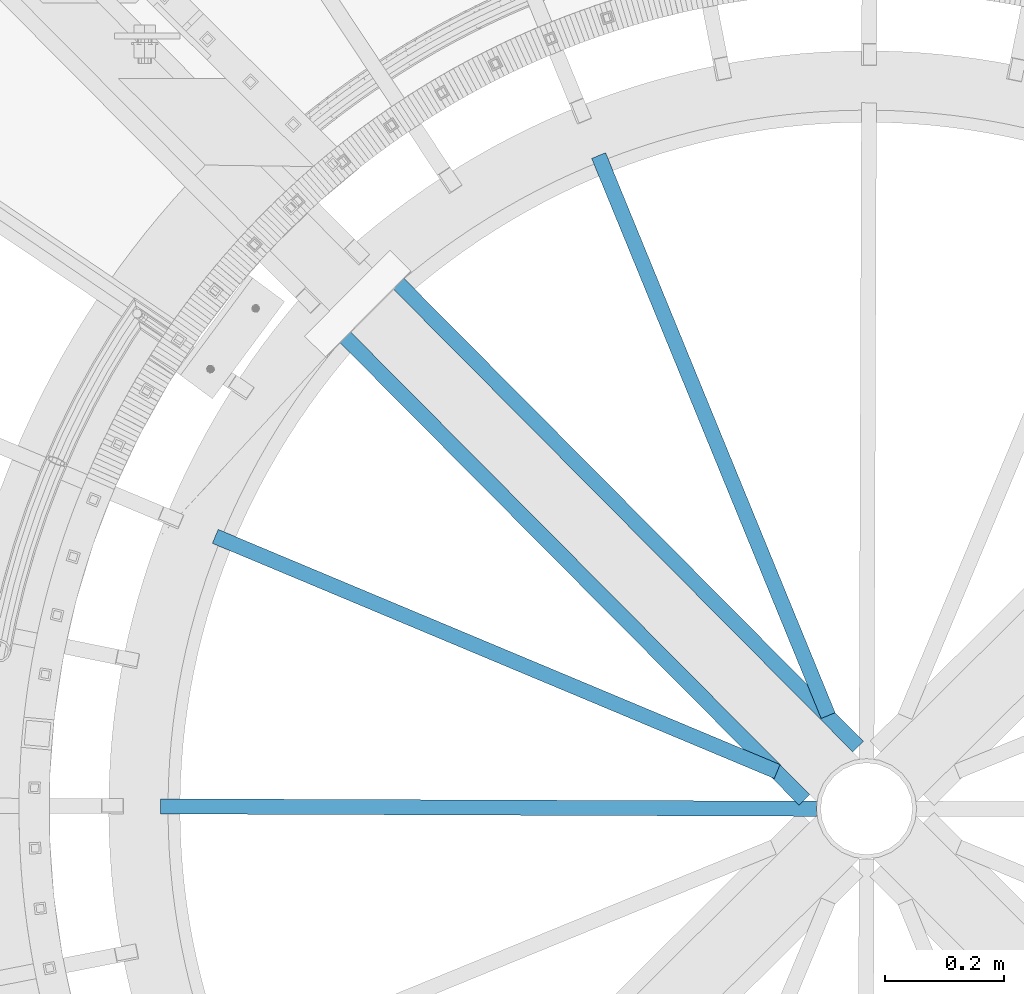
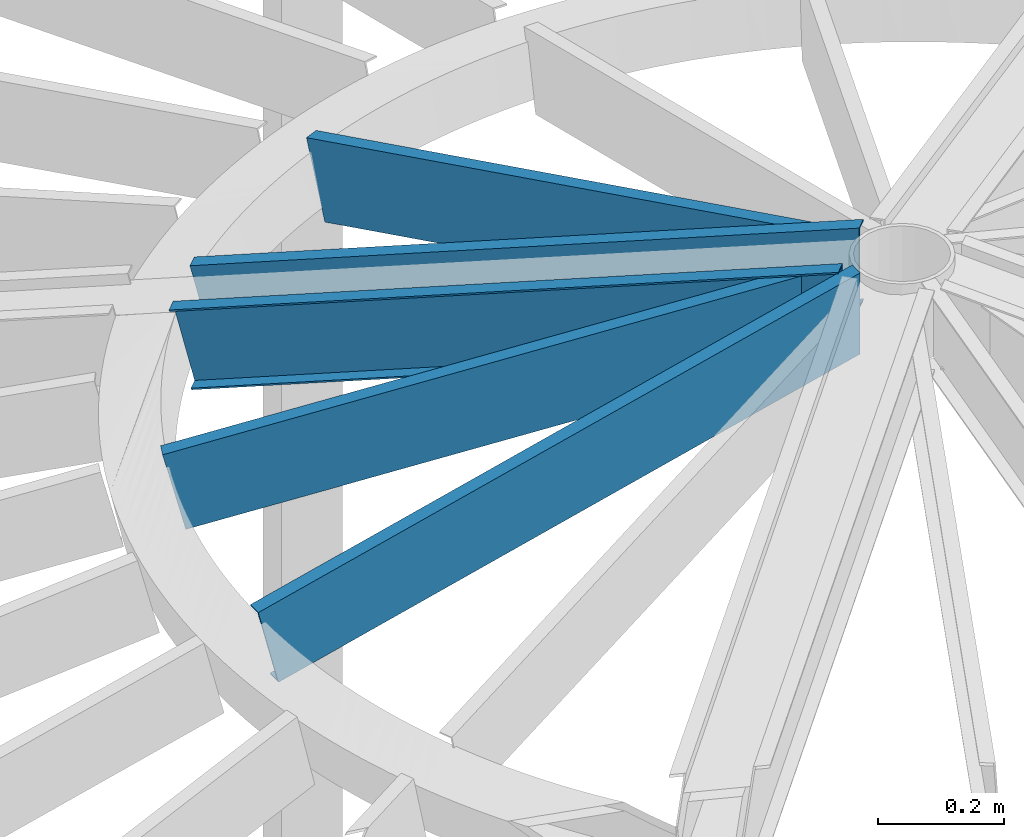
# One storey, part 349 of 975: 5 beams.
"""IFC2X3 building model written with IfcOpenShell, lengths in millimetres."""

import ifcopenshell
import ifcopenshell.guid

model = None  # the IFC model being written
_history = None  # IfcOwnerHistory: only IFC2X3 demands one
_inside = {}  # id of a spatial element -> (the spatial element, [elements in it])
_under = {}  # id of a project, library or spatial element -> (it, [spatial elements below it])
_declared = {}  # id of a project -> (the project, [libraries it declares])
_typed = {}  # id of a type object -> (the type object, [elements of that type])
_made_of = {}  # id of a material, layer set ... -> (it, [elements and type objects made of it])


def new_model(schema):
    """Start an empty IFC model of exactly this schema.

    Asked for "IFC4X3", IfcOpenShell would pick the latest addendum, in which some entities
    have other attributes; the version numbers below select the first issue.
    IFC2X3 requires an IfcOwnerHistory on every rooted entity: one is made here for all.
    """
    global model, _history
    if schema == "IFC4X3":
        model = ifcopenshell.file(schema_version=(4, 3, 0, 0))
    else:
        model = ifcopenshell.file(schema=schema)
    _inside.clear()
    _under.clear()
    _declared.clear()
    _typed.clear()
    _made_of.clear()
    _history = None
    if model.schema == "IFC2X3":
        org = make("IfcOrganization", Name="unknown")
        user = make(
            "IfcPersonAndOrganization",
            ThePerson=make("IfcPerson", FamilyName="unknown"),
            TheOrganization=org,
        )
        app = make(
            "IfcApplication",
            ApplicationDeveloper=org,
            Version="unknown",
            ApplicationFullName="unknown",
            ApplicationIdentifier="unknown",
        )
        _history = make(
            "IfcOwnerHistory",
            OwningUser=user,
            OwningApplication=app,
            ChangeAction="ADDED",
            CreationDate=0,
        )
    return model


def make(cls, **values):
    """One entity of the class cls with the attributes given. An attribute that is None is left unset."""
    return model.create_entity(
        cls, **{name: value for name, value in values.items() if value is not None}
    )


def rooted(cls, **values):
    """An entity with a GlobalId (a new one), such as an element, a storey or a relation."""
    return make(cls, GlobalId=ifcopenshell.guid.new(), OwnerHistory=_history, **values)


def si_unit(unit_type, name, prefix=None):
    """IfcSIUnit, for example si_unit("LENGTHUNIT", "METRE", prefix="MILLI")."""
    return make("IfcSIUnit", UnitType=unit_type, Prefix=prefix, Name=name)


def assignment(units):
    """IfcUnitAssignment: the units of a project."""
    return None if units is None else make("IfcUnitAssignment", Units=units)


def point(xyz):
    """IfcCartesianPoint."""
    return None if xyz is None else make("IfcCartesianPoint", Coordinates=xyz)


def direction(xyz):
    """IfcDirection."""
    return None if xyz is None else make("IfcDirection", DirectionRatios=xyz)


def frame(location, z_axis=None, x_axis=None):
    """IfcAxis2Placement3D, a coordinate frame: its origin and axes. An axis left out is left unset."""
    return make(
        "IfcAxis2Placement3D",
        Location=point(location),
        Axis=direction(z_axis),
        RefDirection=direction(x_axis),
    )


def origin_with_axes():
    """The frame at (0, 0, 0) with the z axis (0, 0, 1) and the x axis (1, 0, 0) written out."""
    return frame((0.0, 0.0, 0.0), z_axis=(0.0, 0.0, 1.0), x_axis=(1.0, 0.0, 0.0))


def place(relative_to, where):
    """IfcLocalPlacement: puts the frame where relative to a parent placement (None: the world)."""
    return make(
        "IfcLocalPlacement", PlacementRelTo=relative_to, RelativePlacement=where
    )


def context(
    kind, dimensions, precision=None, world=None, true_north=None, identifier=None
):
    """IfcGeometricRepresentationContext, for example the 3D "Model" context."""
    return make(
        "IfcGeometricRepresentationContext",
        ContextIdentifier=identifier,
        ContextType=kind,
        CoordinateSpaceDimension=dimensions,
        Precision=precision,
        WorldCoordinateSystem=world,
        TrueNorth=true_north,
    )


def subcontext(parent, identifier, kind, view, scale=None):
    """IfcGeometricRepresentationSubContext, for example "Body" below "Model"."""
    return make(
        "IfcGeometricRepresentationSubContext",
        ContextIdentifier=identifier,
        ContextType=kind,
        ParentContext=parent,
        TargetScale=scale,
        TargetView=view,
    )


def project(units=None, contexts=None):
    """IfcProject with its units and contexts."""
    return rooted(
        "IfcProject",
        Name="project",
        RepresentationContexts=contexts,
        UnitsInContext=assignment(units),
    )


def spatial(cls, under=None, at=None, **own):
    """A site, building, storey or space (cls), placed at a placement, below another one or the project."""
    s = rooted(cls, ObjectPlacement=at, **own)
    if under is not None:
        _under.setdefault(under.id(), (under, []))[1].append(s)
    return s


def faces_of(points, faces, orient=None, outer=None):
    """IfcFace entities. A face is a list of loops; a loop is a list of indices into points, from 0.

    orient and outer hold one flag for each loop. By default every Orientation is true, the
    first loop of a face is its IfcFaceOuterBound and the others are IfcFaceBound.
    """
    made = []
    for i, loops in enumerate(faces):
        bounds = []
        for j, loop in enumerate(loops):
            is_outer = j == 0 if outer is None else outer[i][j]
            bounds.append(
                make(
                    "IfcFaceOuterBound" if is_outer else "IfcFaceBound",
                    Bound=make("IfcPolyLoop", Polygon=[points[k] for k in loop]),
                    Orientation=True if orient is None else orient[i][j],
                )
            )
        made.append(make("IfcFace", Bounds=bounds))
    return made


def faceted_brep(points, faces, orient=None, outer=None, voids=None):
    """IfcFacetedBrep: a solid bounded by flat faces; with voids (closed shells), ...WithVoids."""
    shared = [point(p) for p in points]
    hull = make("IfcClosedShell", CfsFaces=faces_of(shared, faces, orient, outer))
    if voids is None:
        return make("IfcFacetedBrep", Outer=hull)
    return make(
        "IfcFacetedBrepWithVoids",
        Outer=hull,
        Voids=[
            make(cls, CfsFaces=faces_of(shared, fs, o, b)) for cls, fs, o, b in voids
        ],
    )


def shape(context_of_items, identifier, shape_type, items):
    """IfcShapeRepresentation: the items that make up one representation, for example the "Body"."""
    return make(
        "IfcShapeRepresentation",
        ContextOfItems=context_of_items,
        RepresentationIdentifier=identifier,
        RepresentationType=shape_type,
        Items=items,
    )


def material(Name=None, Category=None):
    """IfcMaterial."""
    return make("IfcMaterial", Name=Name, Category=Category)


def made_of(thing, what):
    """Note that an element or type object is made of a material, layer set ...; save() writes the relation."""
    if what is not None:
        _made_of.setdefault(what.id(), (what, []))[1].append(thing)
    return thing


def type_object(cls, material=None, **own):
    """A type object (cls), such as IfcWallType, which elements share."""
    return made_of(rooted(cls, **own), material)


def element(
    cls,
    number,
    at=None,
    inside=None,
    cuts=None,
    type_object=None,
    material=None,
    context=None,
    identifier="Body",
    shape_type=None,
    held_by="IfcProductDefinitionShape",
    body=None,
    shapes=None,
    **own,
):
    """One element of the class cls, such as IfcWall. Its Tag is "e" and its number.

    at: its placement. inside: the storey or other place that contains it. cuts: it is an
    opening in that element (IfcRelVoidsElement). A single representation is given by context,
    identifier, shape_type and body (its items); several are given by shapes. held_by: the class
    of the entity that holds the representations. save() writes the other relations.
    """
    e = rooted(cls, Tag="e%d" % number, ObjectPlacement=at, **own)
    if body is not None:
        shapes = [shape(context, identifier, shape_type, body)]
    if shapes is not None:
        e.Representation = make(held_by, Representations=shapes)
    if inside is not None:
        _inside.setdefault(inside.id(), (inside, []))[1].append(e)
    if cuts is not None:
        rooted(
            "IfcRelVoidsElement", RelatingBuildingElement=cuts, RelatedOpeningElement=e
        )
    if type_object is not None:
        _typed.setdefault(type_object.id(), (type_object, []))[1].append(e)
    return made_of(e, material)


def aggregate(whole, parts):
    """IfcRelAggregates: a whole, such as a stair, and the parts it consists of."""
    return rooted("IfcRelAggregates", RelatingObject=whole, RelatedObjects=parts)


def save(model, path):
    """Write the relations noted so far, then the file.

    IfcRelAggregates (storeys below a building ...), IfcRelContainedInSpatialStructure (elements
    in a storey), IfcRelDefinesByType, IfcRelAssociatesMaterial and IfcRelDeclares: one each for
    every whole, place, type object, material and project.
    """
    for whole, parts in _under.values():
        aggregate(whole, parts)
    for where, things in _inside.values():
        rooted(
            "IfcRelContainedInSpatialStructure",
            RelatedElements=things,
            RelatingStructure=where,
        )
    for kind, things in _typed.values():
        rooted("IfcRelDefinesByType", RelatedObjects=things, RelatingType=kind)
    for what, things in _made_of.values():
        rooted("IfcRelAssociatesMaterial", RelatedObjects=things, RelatingMaterial=what)
    for by, libraries in _declared.values():
        rooted("IfcRelDeclares", RelatingContext=by, RelatedDefinitions=libraries)
    model.write(path)


model = new_model("IFC2X3")

# Units and contexts
model_context = context("Model", 3, precision=1e-05, world=origin_with_axes())
body_context = subcontext(model_context, "Body", "Model", "MODEL_VIEW")
ifc_project = project(units=[si_unit("LENGTHUNIT", "METRE", prefix="MILLI"), si_unit("AREAUNIT", "SQUARE_METRE"), si_unit("VOLUMEUNIT", "CUBIC_METRE"), si_unit("MASSUNIT", "GRAM", prefix="KILO"), si_unit("TIMEUNIT", "SECOND"), si_unit("PLANEANGLEUNIT", "RADIAN"), si_unit("SOLIDANGLEUNIT", "STERADIAN"), si_unit("THERMODYNAMICTEMPERATUREUNIT", "DEGREE_CELSIUS"), si_unit("LUMINOUSINTENSITYUNIT", "LUMEN")], contexts=[model_context])

# Site, building, storey
site_placement = place(None, origin_with_axes())
site = spatial("IfcSite", under=ifc_project, at=site_placement, CompositionType="ELEMENT")
building_placement = place(site_placement, origin_with_axes())
building = spatial("IfcBuilding", under=site, at=building_placement, Name="Undefined", CompositionType="ELEMENT")
storey_placement = place(building_placement, origin_with_axes())
storey = spatial("IfcBuildingStorey", under=building, at=storey_placement, Name="Undefined", CompositionType="ELEMENT", Elevation=0.0)

# Beams
ifc_material = material(Name="STEEL/Zero_Density")
beam_type = type_object("IfcBeamType", PredefinedType="NOTDEFINED")
beam_1_placement = place(storey_placement, frame((34673.9151819895, 3428.57975166967, 9185.06096723024), z_axis=(-0.223737955733079, 0.0936371633068038, 0.970140922140819), x_axis=(-0.894927076878677, 0.374538296949224, -0.242541936967119)))
element("IfcBeam", 1, at=beam_1_placement, inside=storey, type_object=beam_type, material=ifc_material, Name="STUD", context=body_context, shape_type="Brep", body=[
    faceted_brep([(1134.70057945789, -12.6999999990348, 76.200000000108), (1134.70057945789, -12.6999999990367, 73.0250000001097), (1134.70057945792, 9.52500000095824, 73.025000000097), (1134.70057945806, 9.52500000092914, -73.0249999998405), (1134.70057945804, -12.6999999990658, -73.0249999998296), (1134.70057945805, -12.6999999990658, -76.1999999998279), (1134.70057945806, 12.7000000009302, -76.1999999998443), (1134.70057945791, 12.700000000963, 76.2000000000953), (119.0760400088, -12.6999999999716, -76.1999999999782), (119.076040046944, 12.6999999999971, -76.2000000000055), (80.9749864673286, 12.6999999999971, 76.2000000001033), (80.974986429188, -12.6999999999716, 76.2000000001315), (81.7687583787665, -12.6999999999716, 73.0250000001286), (81.7687584121413, 9.52500000000146, 73.0250000001067), (118.2822680926, 9.52500000000146, -73.0250000000008), (118.282268059225, -12.6999999999716, -73.0249999999753)], [[[0, 1, 2, 3, 4, 5, 6, 7]], [[6, 5, 8, 9]], [[7, 6, 9, 10]], [[0, 7, 10, 11]], [[1, 0, 11, 12]], [[2, 1, 12, 13]], [[3, 2, 13, 14]], [[4, 3, 14, 15]], [[5, 4, 15, 8]], [[14, 13, 12, 11, 10, 9, 8, 15]]]),
])
beam_2_placement = place(storey_placement, frame((34709.3234161458, 3464.10328745014, 9185.06096723024), z_axis=(-0.091995151989293, 0.224418098973874, 0.970140922167197), x_axis=(-0.367970434790039, 0.897647574487811, -0.242541936861608)))
element("IfcBeam", 2, at=beam_2_placement, inside=storey, type_object=beam_type, material=ifc_material, Name="STUD", context=body_context, shape_type="Brep", body=[
    faceted_brep([(1134.70057945789, -12.6999999990348, 76.200000000108), (1134.70057945789, -12.6999999990367, 73.0250000001097), (1134.70057945792, 9.52500000095824, 73.025000000097), (1134.70057945806, 9.52500000092914, -73.0249999998405), (1134.70057945804, -12.6999999990658, -73.0249999998296), (1134.70057945805, -12.6999999990658, -76.1999999998279), (1134.70057945806, 12.7000000009302, -76.1999999998443), (1134.70057945791, 12.700000000963, 76.2000000000953), (125.830470330438, -12.699999999908, -76.199999999948), (125.830470360648, 12.700000000088, -76.1999999999616), (87.7294169224115, 12.7000000000862, 76.1999999999744), (87.7294168921944, -12.699999999908, 76.1999999999871), (88.5231888388298, -12.6999999999098, 73.0249999999878), (88.5231888652634, 9.52500000008513, 73.024999999976), (125.036698410244, 9.52500000008877, -73.0249999999596), (125.03669838381, -12.6999999999061, -73.0249999999487)], [[[0, 1, 2, 3, 4, 5, 6, 7]], [[6, 5, 8, 9]], [[7, 6, 9, 10]], [[0, 7, 10, 11]], [[1, 0, 11, 12]], [[2, 1, 12, 13]], [[3, 2, 13, 14]], [[4, 3, 14, 15]], [[5, 4, 15, 8]], [[14, 13, 12, 11, 10, 9, 8, 15]]]),
])
for number, where, z_axis, x_axis, name in (
    (3, (34668.9675895506, 3403.49347518936, 9185.06096723024), (-0.242540308898344, 0.000888649999627433, 0.970140922165782), (-0.970134410469096, 0.00355450199805463, -0.242541936867269), "STUD"),
    (4, (34733.2188229527, 3494.92984679496, 9185.06096723024), (-0.170873527176511, 0.172130267177808, 0.970140922150774), (-0.683475207795134, 0.688502032793624, -0.242541936927299), "STUD"),
):
    element("IfcBeam", number, at=place(storey_placement, frame(where, z_axis=z_axis, x_axis=x_axis)), inside=storey, type_object=beam_type, material=ifc_material, Name=name, context=body_context, shape_type="Brep", body=[
        faceted_brep([(1134.70057945789, -12.6999999990348, 76.200000000108), (1134.70057945789, -12.6999999990367, 73.0250000001097), (1134.70057945792, 9.52500000095824, 73.025000000097), (1134.70057945806, 9.52500000092914, -73.0249999998405), (1134.70057945804, -12.6999999990658, -73.0249999998296), (1134.70057945805, -12.6999999990658, -76.1999999998279), (1134.70057945806, 12.7000000009302, -76.1999999998443), (1134.70057945791, 12.700000000963, 76.2000000000953), (38.1010538948394, -12.7000000000157, -76.1999999999643), (38.1010539016352, 12.6999999999862, -76.1999999999662), (1.96450855582952e-10, 12.7000000001644, 76.2000000001021), (1.74622982740402e-10, -12.6999999998661, 76.2000000000985), (0.79377234254207, -12.699999999993, 73.0249999999905), (0.793772348486527, 9.52500000000873, 73.0249999999905), (37.3072819528606, 9.52499999998645, -73.0249999999669), (37.3072819469235, -12.7000000000148, -73.0249999999651)], [[[0, 1, 2, 3, 4, 5, 6, 7]], [[6, 5, 8, 9]], [[7, 6, 9, 10]], [[0, 7, 10, 11]], [[1, 0, 11, 12]], [[2, 1, 12, 13]], [[3, 2, 13, 14]], [[4, 3, 14, 15]], [[5, 4, 15, 8]], [[14, 13, 12, 11, 10, 9, 8, 15]]]),
    ])
beam_3_placement = place(storey_placement, frame((33867.5952930834, 4186.74740874074, 8909.8484911832), z_axis=(-0.170873527176511, 0.172130267177808, 0.970140922150774), x_axis=(0.683475126987411, -0.688502112987316, 0.242541936995532)))
element("IfcBeam", 5, at=beam_3_placement, inside=storey, type_object=beam_type, material=ifc_material, Name="STUD", context=body_context, shape_type="Brep", body=[
    faceted_brep([(-1.92812876775861e-10, -12.7000000001717, -76.2000000001003), (-1.81898940354586e-10, -12.7000000001608, -73.0250000000965), (-1.60071067512035e-10, 9.52499999986321, -73.0250000000938), (1.89174897968769e-10, 9.52500000015425, 73.0250000000974), (1.67347025126219e-10, -12.6999999998698, 73.0250000000947), (1.74622982740402e-10, -12.6999999998661, 76.2000000000985), (1.96450855582952e-10, 12.7000000001644, 76.2000000001021), (-1.67347025126219e-10, 12.6999999998588, -76.2000000000985), (1134.70057945789, -12.6999999990348, 76.200000000108), (1134.70057945791, 12.700000000963, 76.2000000000953), (1096.59952564954, 12.6999999982763, -76.1999999995651), (1096.59952565276, -12.7000000017433, -76.1999999995523), (1097.39329760113, -12.700000001747, -73.0249999995513), (1097.39329759832, 9.52499999827342, -73.0249999995613), (1133.90680722362, 9.5249999982334, 73.0250000005217), (1133.90680722643, -12.7000000017833, 73.0250000005308)], [[[0, 1, 2, 3, 4, 5, 6, 7]], [[8, 9, 6, 5]], [[7, 6, 9, 10]], [[0, 7, 10, 11]], [[1, 0, 11, 12]], [[2, 1, 12, 13]], [[3, 2, 13, 14]], [[4, 3, 14, 15]], [[5, 4, 15, 8]], [[14, 13, 12, 11, 10, 9, 8, 15]]]),
])

save(model, "model.ifc")
